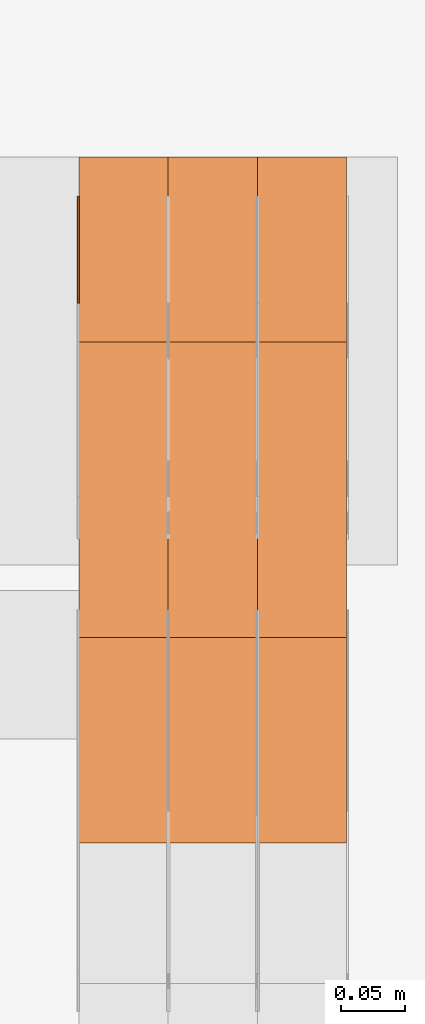
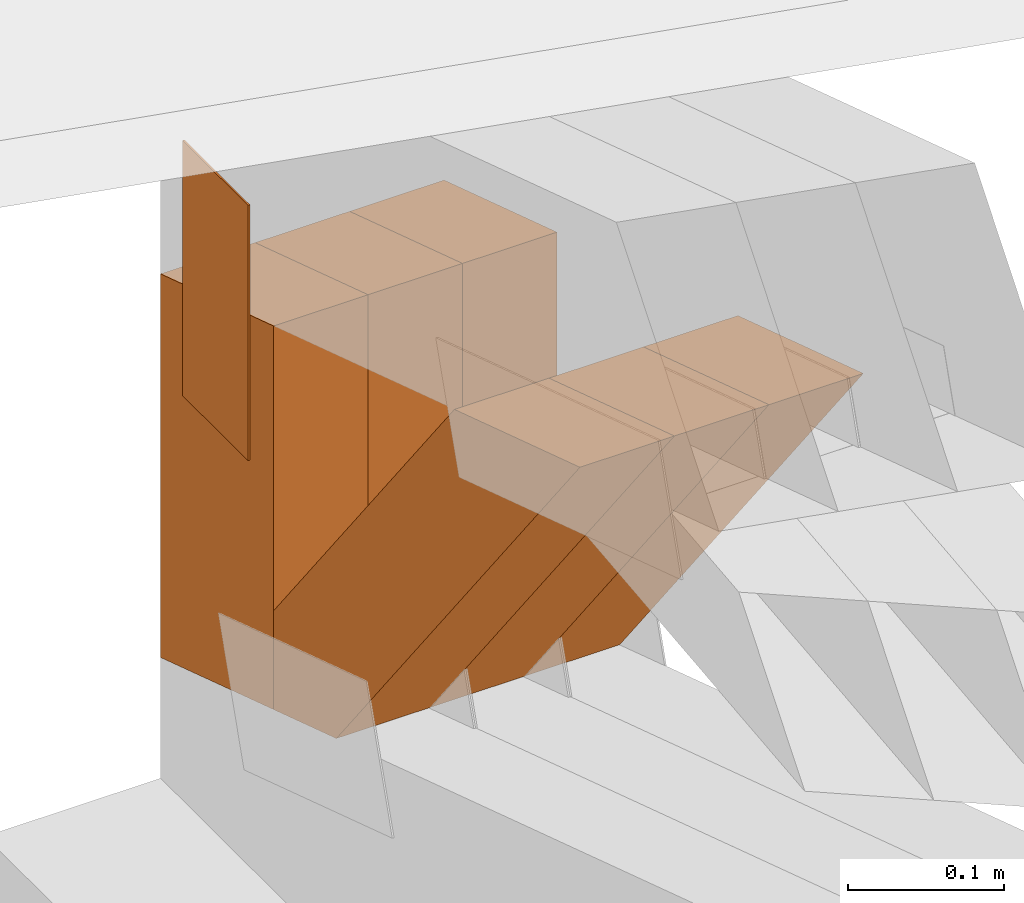
# One storey, part 377 of 385: 7 proxies.
"""IFC2X3 building model written with IfcOpenShell, lengths in millimetres."""

from ifc_helpers import new_model, entity, si_unit, converted_unit, derived_unit, direction, frame, frame_2d, origin, place, context, subcontext, project, spatial, polyline, rectangle, outline, extrude, source, transform, mapped, material, type_object, type_shapes, element, save


model = new_model("IFC2X3")

# Units and contexts
model_context = context("Model", 3, precision=0.01, world=origin(), true_north=direction((6.12303176911189e-17, 1.0)))
body_context = subcontext(model_context, "Body", "Model", "MODEL_VIEW")
ifc_project = project(units=[si_unit("LENGTHUNIT", "METRE", prefix="MILLI"), si_unit("AREAUNIT", "SQUARE_METRE"), si_unit("VOLUMEUNIT", "CUBIC_METRE"), converted_unit("PLANEANGLEUNIT", "DEGREE", entity("IfcRatioMeasure", 0.0174532925199433), si_unit("PLANEANGLEUNIT", "RADIAN"), dimensions=[0, 0, 0, 0, 0, 0, 0]), si_unit("MASSUNIT", "GRAM", prefix="KILO"), derived_unit("MASSDENSITYUNIT", [(si_unit("MASSUNIT", "GRAM", prefix="KILO"), 1), (si_unit("LENGTHUNIT", "METRE"), -3)]), si_unit("TIMEUNIT", "SECOND"), si_unit("FREQUENCYUNIT", "HERTZ"), si_unit("THERMODYNAMICTEMPERATUREUNIT", "DEGREE_CELSIUS"), derived_unit("THERMALTRANSMITTANCEUNIT", [(si_unit("MASSUNIT", "GRAM", prefix="KILO"), 1), (si_unit("THERMODYNAMICTEMPERATUREUNIT", "KELVIN"), -1), (si_unit("TIMEUNIT", "SECOND"), -3)]), derived_unit("VOLUMETRICFLOWRATEUNIT", [(si_unit("LENGTHUNIT", "METRE"), 3), (si_unit("TIMEUNIT", "SECOND"), -1)]), si_unit("ELECTRICCURRENTUNIT", "AMPERE"), si_unit("ELECTRICVOLTAGEUNIT", "VOLT"), si_unit("POWERUNIT", "WATT"), si_unit("FORCEUNIT", "NEWTON", prefix="KILO"), si_unit("ILLUMINANCEUNIT", "LUX"), si_unit("LUMINOUSFLUXUNIT", "LUMEN"), si_unit("LUMINOUSINTENSITYUNIT", "CANDELA"), derived_unit("USERDEFINED", [(si_unit("MASSUNIT", "GRAM", prefix="KILO"), -1), (si_unit("LENGTHUNIT", "METRE"), -2), (si_unit("TIMEUNIT", "SECOND"), 3), (si_unit("LUMINOUSFLUXUNIT", "LUMEN"), 1)]), derived_unit("LINEARVELOCITYUNIT", [(si_unit("LENGTHUNIT", "METRE"), 1), (si_unit("TIMEUNIT", "SECOND"), -1)]), si_unit("PRESSUREUNIT", "PASCAL"), derived_unit("USERDEFINED", [(si_unit("LENGTHUNIT", "METRE"), -2), (si_unit("MASSUNIT", "GRAM", prefix="KILO"), 1), (si_unit("TIMEUNIT", "SECOND"), -2)])], contexts=[model_context])

# Site, building, storey
site_placement = place(None, origin())
site = spatial("IfcSite", under=ifc_project, at=site_placement, CompositionType="ELEMENT")
building_placement = place(site_placement, origin())
building = spatial("IfcBuilding", under=site, at=building_placement, CompositionType="ELEMENT")
storey_placement = place(building_placement, origin())
storey = spatial("IfcBuildingStorey", under=building, at=storey_placement, Name="Default", CompositionType="ELEMENT", Elevation=0.0)

# Proxies
ifc_material_1 = material(Name="IfcSurfaceStyle #605965")
building_element_proxy_type_1 = type_object("IfcBuildingElementProxyType", PredefinedType="NOTDEFINED", material=ifc_material_1)
shared_shape_1 = source(origin(), body_context, "Body", "SweptSolid", [
    extrude(rectangle(XDim=200.0, YDim=84.0000000000005, at=frame_2d((-2.1316282072803e-14, 1.06581410364015e-14), x_axis=(1.0, 0.0))), frame((100.0, 42.0, 0.0), z_axis=(0.0, 0.0, 1.0), x_axis=(-1.0, 0.0, 0.0)), (0.0, 0.0, 1.0), 1.29999999999999),
])
type_shapes(building_element_proxy_type_1, [shared_shape_1])
proxy_1_placement = place(building_placement, frame((49650.0, 26469.5000000002, 518.521545410156), z_axis=(-1.0, 0.0, 0.0), x_axis=(0.0, 0.0, -1.0)))
element("IfcBuildingElementProxy", 1, at=proxy_1_placement, inside=storey, type_object=building_element_proxy_type_1, material=ifc_material_1, context=body_context, shape_type="MappedRepresentation", body=[
    mapped(shared_shape_1, transform((0.0, 0.0, 0.0), scale=1.0)),
])
ifc_material_2 = material(Name="IfcSurfaceStyle #594442")
building_element_proxy_type_2 = type_object("IfcBuildingElementProxyType", Name="T2-W21 594440", PredefinedType="NOTDEFINED", material=ifc_material_2)
shared_shape_2 = source(origin(), body_context, "Body", "SweptSolid", [
    extrude(outline(polyline([(-209.199362597501, -47.5000308982766), (168.813164734153, -47.5000308982766), (229.900717355638, -2.18385470334148e-05), (159.828709317766, 47.5000418175501), (-349.343228810055, 47.5000418175502), (-209.199362597501, -47.5000308982766)])), frame((229.900720156071, 47.5000418175501, 0.0), z_axis=(0.0, 0.0, 1.0), x_axis=(-1.0, 0.0, 0.0)), (0.0, 0.0, 1.0), 70.0),
])
type_shapes(building_element_proxy_type_2, [shared_shape_2])
proxy_2_placement = place(building_placement, frame((49860.0, 26317.5019908272, 112.518372832984), z_axis=(-1.0, 0.0, 0.0), x_axis=(0.0, -0.613839629272042, 0.789430750310097)))
element("IfcBuildingElementProxy", 2, at=proxy_2_placement, inside=storey, type_object=building_element_proxy_type_2, material=ifc_material_2, Name="T2-W21", context=body_context, shape_type="MappedRepresentation", body=[
    mapped(shared_shape_2, transform((0.0, 0.0, 0.0), scale=1.0)),
])
ifc_material_3 = material(Name="IfcSurfaceStyle #594376")
building_element_proxy_type_3 = type_object("IfcBuildingElementProxyType", Name="T2-W21 594374", PredefinedType="NOTDEFINED", material=ifc_material_3)
shared_shape_3 = source(origin(), body_context, "Body", "SweptSolid", [
    extrude(outline(polyline([(-209.199362597501, -47.5000308982766), (168.813164734153, -47.5000308982766), (229.900717355638, -2.18385470334148e-05), (159.828709317766, 47.5000418175501), (-349.343228810055, 47.5000418175502), (-209.199362597501, -47.5000308982766)])), frame((229.900720156071, 47.5000418175501, 0.0), z_axis=(0.0, 0.0, 1.0), x_axis=(-1.0, 0.0, 0.0)), (0.0, 0.0, 1.0), 70.0),
])
type_shapes(building_element_proxy_type_3, [shared_shape_3])
proxy_3_placement = place(building_placement, frame((49790.0, 26317.5019908272, 112.518372832984), z_axis=(-1.0, 0.0, 0.0), x_axis=(0.0, -0.613839629272042, 0.789430750310097)))
element("IfcBuildingElementProxy", 3, at=proxy_3_placement, inside=storey, type_object=building_element_proxy_type_3, material=ifc_material_3, Name="T2-W21", context=body_context, shape_type="MappedRepresentation", body=[
    mapped(shared_shape_3, transform((0.0, 0.0, 0.0), scale=1.0)),
])
ifc_material_4 = material(Name="IfcSurfaceStyle #594310")
building_element_proxy_type_4 = type_object("IfcBuildingElementProxyType", Name="T2-W21 594308", PredefinedType="NOTDEFINED", material=ifc_material_4)
shared_shape_4 = source(origin(), body_context, "Body", "SweptSolid", [
    extrude(outline(polyline([(-209.199362597501, -47.5000308982766), (168.813164734153, -47.5000308982766), (229.900717355638, -2.18385470334148e-05), (159.828709317766, 47.5000418175501), (-349.343228810055, 47.5000418175502), (-209.199362597501, -47.5000308982766)])), frame((229.900720156071, 47.5000418175501, 0.0), z_axis=(0.0, 0.0, 1.0), x_axis=(-1.0, 0.0, 0.0)), (0.0, 0.0, 1.0), 70.0),
])
type_shapes(building_element_proxy_type_4, [shared_shape_4])
proxy_4_placement = place(building_placement, frame((49720.0, 26317.5019908272, 112.518372832984), z_axis=(-1.0, 0.0, 0.0), x_axis=(0.0, -0.613839629272042, 0.789430750310097)))
element("IfcBuildingElementProxy", 4, at=proxy_4_placement, inside=storey, type_object=building_element_proxy_type_4, material=ifc_material_4, Name="T2-W21", context=body_context, shape_type="MappedRepresentation", body=[
    mapped(shared_shape_4, transform((0.0, 0.0, 0.0), scale=1.0)),
])
ifc_material_5 = material(Name="IfcSurfaceStyle #593875")
building_element_proxy_type_5 = type_object("IfcBuildingElementProxyType", Name="T2-E2 593873", PredefinedType="NOTDEFINED", material=ifc_material_5)
shared_shape_5 = source(origin(), body_context, "Body", "SweptSolid", [
    extrude(outline(polyline([(-126.644535064697, -72.4999999999998), (173.757884979248, -72.4999999999998), (126.644542694092, 72.4999999999998), (-173.757892608642, 72.4999999999998), (-126.644535064697, -72.4999999999998)])), frame((173.757890653796, 72.5000000000002, 0.0), z_axis=(0.0, 0.0, 1.0), x_axis=(-1.0, 0.0, 0.0)), (0.0, 0.0, 1.0), 70.0),
])
type_shapes(building_element_proxy_type_5, [shared_shape_5])
proxy_5_placement = place(building_placement, frame((49860.0, 26500.0, 442.078222227283), z_axis=(-1.0, 0.0, 0.0), x_axis=(0.0, 0.0, -1.0)))
element("IfcBuildingElementProxy", 5, at=proxy_5_placement, inside=storey, type_object=building_element_proxy_type_5, material=ifc_material_5, Name="T2-E2", context=body_context, shape_type="MappedRepresentation", body=[
    mapped(shared_shape_5, transform((0.0, 0.0, 0.0), scale=1.0)),
])
ifc_material_6 = material(Name="IfcSurfaceStyle #593818")
building_element_proxy_type_6 = type_object("IfcBuildingElementProxyType", Name="T2-E2 593816", PredefinedType="NOTDEFINED", material=ifc_material_6)
shared_shape_6 = source(origin(), body_context, "Body", "SweptSolid", [
    extrude(outline(polyline([(-126.644535064697, -72.4999999999998), (173.757884979248, -72.4999999999998), (126.644542694092, 72.4999999999998), (-173.757892608642, 72.4999999999998), (-126.644535064697, -72.4999999999998)])), frame((173.757890653796, 72.5000000000002, 0.0), z_axis=(0.0, 0.0, 1.0), x_axis=(-1.0, 0.0, 0.0)), (0.0, 0.0, 1.0), 70.0),
])
type_shapes(building_element_proxy_type_6, [shared_shape_6])
proxy_6_placement = place(building_placement, frame((49790.0, 26500.0, 442.078222227283), z_axis=(-1.0, 0.0, 0.0), x_axis=(0.0, 0.0, -1.0)))
element("IfcBuildingElementProxy", 6, at=proxy_6_placement, inside=storey, type_object=building_element_proxy_type_6, material=ifc_material_6, Name="T2-E2", context=body_context, shape_type="MappedRepresentation", body=[
    mapped(shared_shape_6, transform((0.0, 0.0, 0.0), scale=1.0)),
])
ifc_material_7 = material(Name="IfcSurfaceStyle #593761")
building_element_proxy_type_7 = type_object("IfcBuildingElementProxyType", Name="T2-E2 593759", PredefinedType="NOTDEFINED", material=ifc_material_7)
shared_shape_7 = source(origin(), body_context, "Body", "SweptSolid", [
    extrude(outline(polyline([(-126.644535064697, -72.4999999999998), (173.757884979248, -72.4999999999998), (126.644542694092, 72.4999999999998), (-173.757892608642, 72.4999999999998), (-126.644535064697, -72.4999999999998)])), frame((173.757890653796, 72.5000000000002, 0.0), z_axis=(0.0, 0.0, 1.0), x_axis=(-1.0, 0.0, 0.0)), (0.0, 0.0, 1.0), 70.0),
])
type_shapes(building_element_proxy_type_7, [shared_shape_7])
proxy_7_placement = place(building_placement, frame((49720.0, 26500.0, 442.078222227283), z_axis=(-1.0, 0.0, 0.0), x_axis=(0.0, 0.0, -1.0)))
element("IfcBuildingElementProxy", 7, at=proxy_7_placement, inside=storey, type_object=building_element_proxy_type_7, material=ifc_material_7, Name="T2-E2", context=body_context, shape_type="MappedRepresentation", body=[
    mapped(shared_shape_7, transform((0.0, 0.0, 0.0), scale=1.0)),
])

save(model, "model.ifc")
